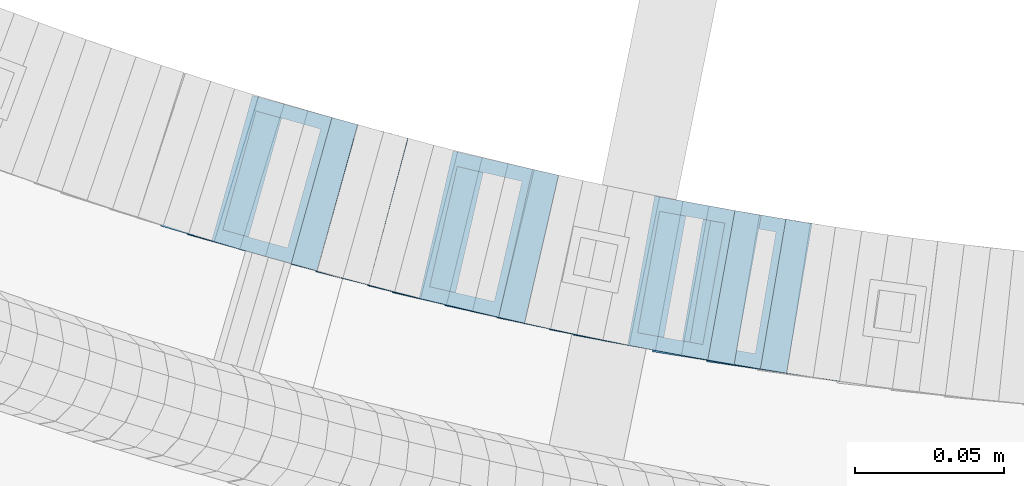
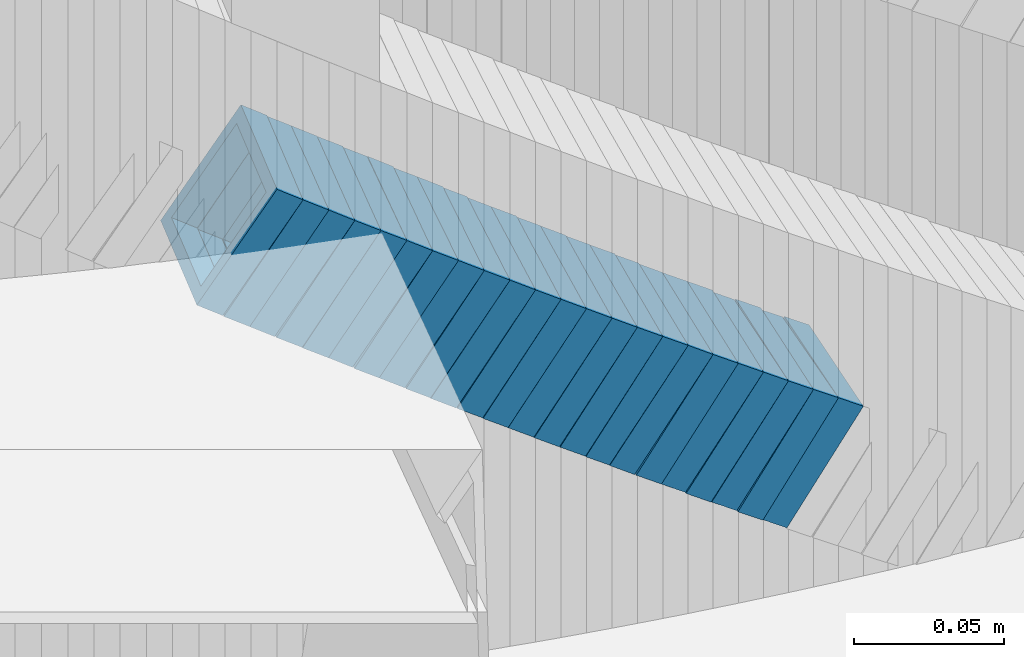
# One storey, part 696 of 975: 23 members.
"""IFC2X3 building model written with IfcOpenShell, lengths in millimetres."""

from ifc_helpers import new_model, si_unit, frame, origin_with_axes, place, context, subcontext, project, spatial, faceted_brep, material, type_object, element, save


model = new_model("IFC2X3")

# Units and contexts
model_context = context("Model", 3, precision=1e-05, world=origin_with_axes())
body_context = subcontext(model_context, "Body", "Model", "MODEL_VIEW")
ifc_project = project(units=[si_unit("LENGTHUNIT", "METRE", prefix="MILLI"), si_unit("AREAUNIT", "SQUARE_METRE"), si_unit("VOLUMEUNIT", "CUBIC_METRE"), si_unit("MASSUNIT", "GRAM", prefix="KILO"), si_unit("TIMEUNIT", "SECOND"), si_unit("PLANEANGLEUNIT", "RADIAN"), si_unit("SOLIDANGLEUNIT", "STERADIAN"), si_unit("THERMODYNAMICTEMPERATUREUNIT", "DEGREE_CELSIUS"), si_unit("LUMINOUSINTENSITYUNIT", "LUMEN")], contexts=[model_context])

# Site, building, storey
site_placement = place(None, origin_with_axes())
site = spatial("IfcSite", under=ifc_project, at=site_placement, CompositionType="ELEMENT")
building_placement = place(site_placement, origin_with_axes())
building = spatial("IfcBuilding", under=site, at=building_placement, Name="Undefined", CompositionType="ELEMENT")
storey_placement = place(building_placement, origin_with_axes())
storey = spatial("IfcBuildingStorey", under=building, at=storey_placement, Name="Undefined", CompositionType="ELEMENT", Elevation=0.0)

# Members
ifc_material = material()
member_type = type_object("IfcMemberType", Name="HSS2X2X.188_TUBES", PredefinedType="NOTDEFINED")
member_1_placement = place(storey_placement, frame((34331.0974043812, 2065.91835474351, 3551.88028193762), z_axis=(-0.279142363058039, -0.960249728532309, 1.20638560474617e-10), x_axis=(-0.805994231967301, 0.234300648990504, 0.543577504977965)))
element("IfcMember", 1, at=member_1_placement, inside=storey, type_object=member_type, material=ifc_material, Name="WALL", ObjectType="HSS2X2X.188_TUBES", context=body_context, shape_type="Brep", body=[
    faceted_brep([(0.0, 20.6374999999753, -20.6375000000298), (0.0, -20.6375000000153, -20.6375000000153), (10.6709887076922, -20.6374999999844, -20.6374999999825), (10.6709887076995, 20.6375000000171, -20.6374999999753), (0.0, -20.6374999999825, 20.6375000000335), (10.6709887076922, -20.6374999999971, 20.6375000000153), (0.0, 20.6375000000116, 20.6375000000189), (10.6709887076941, 20.6375000000025, 20.6375000000189), (0.0, 25.3999999999724, -25.4000000000342), (0.0, 25.400000000016, 25.4000000000196), (10.6709887076959, 25.3999999999996, 25.4000000000233), (10.6709887077013, 25.4000000000178, -25.3999999999724), (0.0, -25.399999999976, 25.4000000000378), (10.6709887076904, -25.3999999999978, 25.400000000016), (0.0, -25.400000000016, -25.4000000000196), (10.6709887076959, -25.3999999999796, -25.3999999999796)], [[[0, 1, 2, 3]], [[1, 4, 5, 2]], [[4, 6, 7, 5]], [[6, 0, 3, 7]], [[8, 9, 10, 11]], [[9, 12, 13, 10]], [[12, 14, 15, 13]], [[14, 8, 11, 15]], [[13, 15, 11, 10], [5, 7, 3, 2]], [[14, 12, 9, 8], [6, 4, 1, 0]]]),
])
member_2_placement = place(storey_placement, frame((34339.5281261376, 2063.41295702112, 3546.09074375081), z_axis=(-0.268798967652496, -0.96319630137836, -2.7861005946761e-10), x_axis=(-0.811862852083943, 0.226566377023422, 0.538095146055609)))
element("IfcMember", 2, at=member_2_placement, inside=storey, type_object=member_type, material=ifc_material, Name="WALL", ObjectType="HSS2X2X.188_TUBES", context=body_context, shape_type="Brep", body=[
    faceted_brep([(0.0, 20.6374999999753, -20.6375000000298), (0.0, -20.6375000000153, -20.6375000000153), (10.5948100501191, -20.6375000000335, -20.6375000000844), (10.5948100501555, 20.6374999999971, -20.6375000000116), (0.0, -20.6374999999825, 20.6375000000335), (10.5948100501446, -20.6375000000098, 20.6374999999571), (0.0, 20.6375000000116, 20.6375000000189), (10.5948100501828, 20.6375000000189, 20.6375000000298), (0.0, 25.3999999999724, -25.4000000000342), (0.0, 25.400000000016, 25.4000000000196), (10.5948100501919, 25.4000000000251, 25.4000000000451), (10.5948100501591, 25.3999999999978, -25.4000000000051), (0.0, -25.399999999976, 25.4000000000378), (10.5948100501482, -25.4000000000106, 25.3999999999578), (0.0, -25.400000000016, -25.4000000000196), (10.5948100501118, -25.4000000000378, -25.400000000096)], [[[0, 1, 2, 3]], [[1, 4, 5, 2]], [[4, 6, 7, 5]], [[6, 0, 3, 7]], [[8, 9, 10, 11]], [[9, 12, 13, 10]], [[12, 14, 15, 13]], [[14, 8, 11, 15]], [[13, 15, 11, 10], [5, 7, 3, 2]], [[14, 12, 9, 8], [6, 4, 1, 0]]]),
])
member_3_placement = place(storey_placement, frame((34347.9652882428, 2061.05840015453, 3540.39961551129), z_axis=(-0.268798967652496, -0.96319630137836, -2.7861005946761e-10), x_axis=(-0.80773431354215, 0.22541422687225, 0.544751048691214)))
element("IfcMember", 3, at=member_3_placement, inside=storey, type_object=member_type, material=ifc_material, Name="WALL", ObjectType="HSS2X2X.188_TUBES", context=body_context, shape_type="Brep", body=[
    faceted_brep([(0.0, 20.6374999999753, -20.6375000000298), (0.0, -20.6375000000153, -20.6375000000153), (10.648004507897, -20.6374999999862, -20.637499999968), (10.6480045078188, 20.6374999999771, -20.6375000000808), (0.0, -20.6374999999825, 20.6375000000335), (10.6480045079406, -20.6374999999698, 20.6375000001062), (0.0, 20.6375000000116, 20.6375000000189), (10.6480045078679, 20.6374999999935, 20.6375000000007), (0.0, 25.3999999999724, -25.4000000000342), (0.0, 25.400000000016, 25.4000000000196), (10.6480045078661, 25.3999999999905, 25.4000000000015), (10.648004507806, 25.3999999999705, -25.4000000000997), (0.0, -25.399999999976, 25.4000000000378), (10.6480045079552, -25.3999999999633, 25.4000000001288), (0.0, -25.400000000016, -25.4000000000196), (10.6480045078988, -25.3999999999814, -25.3999999999651)], [[[0, 1, 2, 3]], [[1, 4, 5, 2]], [[4, 6, 7, 5]], [[6, 0, 3, 7]], [[8, 9, 10, 11]], [[9, 12, 13, 10]], [[12, 14, 15, 13]], [[14, 8, 11, 15]], [[13, 15, 11, 10], [5, 7, 3, 2]], [[14, 12, 9, 8], [6, 4, 1, 0]]]),
])
member_4_placement = place(storey_placement, frame((34356.8447522431, 2058.56625931659, 3534.52460536502), z_axis=(-0.265928998080432, -0.963992618218593, 1.22554411063902e-11), x_axis=(-0.815044169709422, 0.224839770919824, 0.533994455809609)))
element("IfcMember", 4, at=member_4_placement, inside=storey, type_object=member_type, material=ifc_material, Name="WALL", ObjectType="HSS2X2X.188_TUBES", context=body_context, shape_type="Brep", body=[
    faceted_brep([(0.0, 20.6374999999753, -20.6375000000298), (0.0, -20.6375000000153, -20.6375000000153), (10.6709887076922, -20.6374999999844, -20.6374999999825), (10.6709887076995, 20.6375000000171, -20.6374999999753), (0.0, -20.6374999999825, 20.6375000000335), (10.6709887076922, -20.6374999999971, 20.6375000000153), (0.0, 20.6375000000116, 20.6375000000189), (10.6709887076941, 20.6375000000025, 20.6375000000189), (0.0, 25.3999999999724, -25.4000000000342), (0.0, 25.400000000016, 25.4000000000196), (10.6709887076959, 25.3999999999996, 25.4000000000233), (10.6709887077013, 25.4000000000178, -25.3999999999724), (0.0, -25.399999999976, 25.4000000000378), (10.6709887076904, -25.3999999999978, 25.400000000016), (0.0, -25.400000000016, -25.4000000000196), (10.6709887076959, -25.3999999999796, -25.3999999999796)], [[[0, 1, 2, 3]], [[1, 4, 5, 2]], [[4, 6, 7, 5]], [[6, 0, 3, 7]], [[8, 9, 10, 11]], [[9, 12, 13, 10]], [[12, 14, 15, 13]], [[14, 8, 11, 15]], [[13, 15, 11, 10], [5, 7, 3, 2]], [[14, 12, 9, 8], [6, 4, 1, 0]]]),
])
member_5_placement = place(storey_placement, frame((34365.2170506888, 2056.2041123414, 3528.84235404607), z_axis=(-0.255587111130459, -0.966786030424513, 1.11640474642627e-11), x_axis=(-0.81673040781737, 0.215917233951713, 0.535099232880326)))
element("IfcMember", 5, at=member_5_placement, inside=storey, type_object=member_type, material=ifc_material, Name="WALL", ObjectType="HSS2X2X.188_TUBES", context=body_context, shape_type="Brep", body=[
    faceted_brep([(0.0, 20.6374999999753, -20.6375000000298), (0.0, -20.6375000000153, -20.6375000000153), (10.648004507897, -20.6374999999862, -20.637499999968), (10.6480045078188, 20.6374999999771, -20.6375000000808), (0.0, -20.6374999999825, 20.6375000000335), (10.6480045079406, -20.6374999999698, 20.6375000001062), (0.0, 20.6375000000116, 20.6375000000189), (10.6480045078679, 20.6374999999935, 20.6375000000007), (0.0, 25.3999999999724, -25.4000000000342), (0.0, 25.400000000016, 25.4000000000196), (10.6480045078661, 25.3999999999905, 25.4000000000015), (10.648004507806, 25.3999999999705, -25.4000000000997), (0.0, -25.399999999976, 25.4000000000378), (10.6480045079552, -25.3999999999633, 25.4000000001288), (0.0, -25.400000000016, -25.4000000000196), (10.6480045078988, -25.3999999999814, -25.3999999999651)], [[[0, 1, 2, 3]], [[1, 4, 5, 2]], [[4, 6, 7, 5]], [[6, 0, 3, 7]], [[8, 9, 10, 11]], [[9, 12, 13, 10]], [[12, 14, 15, 13]], [[14, 8, 11, 15]], [[13, 15, 11, 10], [5, 7, 3, 2]], [[14, 12, 9, 8], [6, 4, 1, 0]]]),
])
member_6_placement = place(storey_placement, frame((34373.6329246341, 2053.99385694625, 3523.21833437151), z_axis=(-0.258361739614913, -0.966048244914899, -2.28051248996053e-10), x_axis=(-0.809414005296683, 0.216471187079332, 0.545883864200112)))
element("IfcMember", 6, at=member_6_placement, inside=storey, type_object=member_type, material=ifc_material, Name="WALL", ObjectType="HSS2X2X.188_TUBES", context=body_context, shape_type="Brep", body=[
    faceted_brep([(0.0, 20.6374999999753, -20.6375000000298), (0.0, -20.6375000000153, -20.6375000000153), (10.6216759506497, -20.637499999968, -20.6374999999534), (10.6216759506497, 20.6375000000262, -20.6374999999643), (0.0, -20.6374999999825, 20.6375000000335), (10.6216759506169, -20.6374999999935, 20.637500000008), (0.0, 20.6375000000116, 20.6375000000189), (10.6216759506242, 20.6375000000007, 20.6374999999971), (0.0, 25.3999999999724, -25.4000000000342), (0.0, 25.400000000016, 25.4000000000196), (10.6216759506169, 25.3999999999978, 25.3999999999869), (10.6216759506533, 25.4000000000269, -25.3999999999614), (0.0, -25.399999999976, 25.4000000000378), (10.6216759506242, -25.3999999999942, 25.4000000000051), (0.0, -25.400000000016, -25.4000000000196), (10.6216759506569, -25.3999999999614, -25.3999999999432)], [[[0, 1, 2, 3]], [[1, 4, 5, 2]], [[4, 6, 7, 5]], [[6, 0, 3, 7]], [[8, 9, 10, 11]], [[9, 12, 13, 10]], [[12, 14, 15, 13]], [[14, 8, 11, 15]], [[13, 15, 11, 10], [5, 7, 3, 2]], [[14, 12, 9, 8], [6, 4, 1, 0]]]),
])
member_7_placement = place(storey_placement, frame((34382.1892508265, 2051.63748919236, 3517.35949972849), z_axis=(-0.245156736609686, -0.969483457566393, 4.429666660144e-10), x_axis=(-0.818354737867747, 0.206940278966542, 0.536163448913352)))
element("IfcMember", 7, at=member_7_placement, inside=storey, type_object=member_type, material=ifc_material, Name="WALL", ObjectType="HSS2X2X.188_TUBES", context=body_context, shape_type="Brep", body=[
    faceted_brep([(0.0, 20.6374999999753, -20.6375000000298), (0.0, -20.6375000000153, -20.6375000000153), (10.6348483769107, -20.637499999988, -20.6374999999825), (10.6348483768415, 20.6374999999734, -20.6375000001026), (0.0, -20.6374999999825, 20.6375000000335), (10.6348483769852, -20.6374999999589, 20.6375000001462), (0.0, 20.6375000000116, 20.6375000000189), (10.6348483769161, 20.6375000000044, 20.6375000000226), (0.0, 25.3999999999724, -25.4000000000342), (0.0, 25.400000000016, 25.4000000000196), (10.6348483769179, 25.4000000000015, 25.4000000000233), (10.6348483768288, 25.3999999999669, -25.4000000001324), (0.0, -25.399999999976, 25.4000000000378), (10.6348483769998, -25.3999999999505, 25.4000000001688), (0.0, -25.400000000016, -25.4000000000196), (10.6348483769107, -25.3999999999887, -25.3999999999833)], [[[0, 1, 2, 3]], [[1, 4, 5, 2]], [[4, 6, 7, 5]], [[6, 0, 3, 7]], [[8, 9, 10, 11]], [[9, 12, 13, 10]], [[12, 14, 15, 13]], [[14, 8, 11, 15]], [[13, 15, 11, 10], [5, 7, 3, 2]], [[14, 12, 9, 8], [6, 4, 1, 0]]]),
])
member_8_placement = place(storey_placement, frame((34390.7254524821, 2049.47890946337, 3511.66775487245), z_axis=(-0.245156736609686, -0.969483457566393, 4.429666660144e-10), x_axis=(-0.814222786177676, 0.205895417044948, 0.542815191118441)))
element("IfcMember", 8, at=member_8_placement, inside=storey, type_object=member_type, material=ifc_material, Name="WALL", ObjectType="HSS2X2X.188_TUBES", context=body_context, shape_type="Brep", body=[
    faceted_brep([(0.0, 20.6374999999753, -20.6375000000298), (0.0, -20.6375000000153, -20.6375000000153), (10.6906501205649, -20.6374999999844, -20.637499999968), (10.690650120574, 20.6375000000098, -20.6374999999716), (0.0, -20.6374999999825, 20.6375000000335), (10.6906501205467, -20.6374999999844, 20.637500000008), (0.0, 20.6375000000116, 20.6375000000189), (10.6906501205558, 20.637500000008, 20.6375000000007), (0.0, 25.3999999999724, -25.4000000000342), (0.0, 25.400000000016, 25.4000000000196), (10.6906501205522, 25.4000000000087, 25.3999999999978), (10.6906501205813, 25.4000000000124, -25.3999999999651), (0.0, -25.399999999976, 25.4000000000378), (10.6906501205431, -25.3999999999833, 25.4000000000051), (0.0, -25.400000000016, -25.4000000000196), (10.6906501205704, -25.3999999999833, -25.3999999999614)], [[[0, 1, 2, 3]], [[1, 4, 5, 2]], [[4, 6, 7, 5]], [[6, 0, 3, 7]], [[8, 9, 10, 11]], [[9, 12, 13, 10]], [[12, 14, 15, 13]], [[14, 8, 11, 15]], [[13, 15, 11, 10], [5, 7, 3, 2]], [[14, 12, 9, 8], [6, 4, 1, 0]]]),
])
member_9_placement = place(storey_placement, frame((34399.2614923922, 2047.26637819976, 3505.87602440477), z_axis=(-0.23464053291006, -0.972082208620075, 1.09321263153106e-12), x_axis=(-0.819915965339719, 0.197910750081997, 0.537186322222577)))
element("IfcMember", 9, at=member_9_placement, inside=storey, type_object=member_type, material=ifc_material, Name="WALL", ObjectType="HSS2X2X.188_TUBES", context=body_context, shape_type="Brep", body=[
    faceted_brep([(0.0, 20.6374999999753, -20.6375000000298), (0.0, -20.6375000000153, -20.6375000000153), (10.6061303028146, -20.6374999999571, -20.6374999999643), (10.6061303027491, 20.6374999999971, -20.6375000000007), (0.0, -20.6374999999825, 20.6375000000335), (10.6061303027855, -20.6374999999825, 20.6375000000116), (0.0, 20.6375000000116, 20.6375000000189), (10.6061303027236, 20.637499999968, 20.6374999999716), (0.0, 25.3999999999724, -25.4000000000342), (0.0, 25.400000000016, 25.4000000000196), (10.6061303027163, 25.3999999999651, 25.3999999999651), (10.6061303027454, 25.3999999999942, -25.4000000000051), (0.0, -25.399999999976, 25.4000000000378), (10.6061303027891, -25.3999999999796, 25.4000000000124), (0.0, -25.400000000016, -25.4000000000196), (10.6061303028182, -25.3999999999505, -25.3999999999542)], [[[0, 1, 2, 3]], [[1, 4, 5, 2]], [[4, 6, 7, 5]], [[6, 0, 3, 7]], [[8, 9, 10, 11]], [[9, 12, 13, 10]], [[12, 14, 15, 13]], [[14, 8, 11, 15]], [[13, 15, 11, 10], [5, 7, 3, 2]], [[14, 12, 9, 8], [6, 4, 1, 0]]]),
])
member_10_placement = place(storey_placement, frame((34407.4691510217, 2045.22865012642, 3500.20080520356), z_axis=(-0.224041298984492, -0.974579651105717, -2.52057361649349e-11), x_axis=(-0.817234718278173, 0.187870050063947, 0.544823145185449)))
element("IfcMember", 10, at=member_10_placement, inside=storey, type_object=member_type, material=ifc_material, Name="WALL", ObjectType="HSS2X2X.188_TUBES", context=body_context, shape_type="Brep", body=[
    faceted_brep([(0.0, 20.6374999999753, -20.6375000000298), (0.0, -20.6375000000153, -20.6375000000153), (10.648004507897, -20.6374999999862, -20.637499999968), (10.6480045078188, 20.6374999999771, -20.6375000000808), (0.0, -20.6374999999825, 20.6375000000335), (10.6480045079406, -20.6374999999698, 20.6375000001062), (0.0, 20.6375000000116, 20.6375000000189), (10.6480045078679, 20.6374999999935, 20.6375000000007), (0.0, 25.3999999999724, -25.4000000000342), (0.0, 25.400000000016, 25.4000000000196), (10.6480045078661, 25.3999999999905, 25.4000000000015), (10.648004507806, 25.3999999999705, -25.4000000000997), (0.0, -25.399999999976, 25.4000000000378), (10.6480045079552, -25.3999999999633, 25.4000000001288), (0.0, -25.400000000016, -25.4000000000196), (10.6480045078988, -25.3999999999814, -25.3999999999651)], [[[0, 1, 2, 3]], [[1, 4, 5, 2]], [[4, 6, 7, 5]], [[6, 0, 3, 7]], [[8, 9, 10, 11]], [[9, 12, 13, 10]], [[12, 14, 15, 13]], [[14, 8, 11, 15]], [[13, 15, 11, 10], [5, 7, 3, 2]], [[14, 12, 9, 8], [6, 4, 1, 0]]]),
])
member_11_placement = place(storey_placement, frame((34416.3339171197, 2043.1907728625, 3494.39191048429), z_axis=(-0.224041298984492, -0.974579651105717, -2.52057361649349e-11), x_axis=(-0.82141292979664, 0.188830558953255, 0.538167091866738)))
element("IfcMember", 11, at=member_11_placement, inside=storey, type_object=member_type, material=ifc_material, Name="WALL", ObjectType="HSS2X2X.188_TUBES", context=body_context, shape_type="Brep", body=[
    faceted_brep([(0.0, 20.6374999999753, -20.6375000000298), (0.0, -20.6375000000153, -20.6375000000153), (10.5948100501191, -20.6375000000335, -20.6375000000844), (10.5948100501555, 20.6374999999971, -20.6375000000116), (0.0, -20.6374999999825, 20.6375000000335), (10.5948100501446, -20.6375000000098, 20.6374999999571), (0.0, 20.6375000000116, 20.6375000000189), (10.5948100501828, 20.6375000000189, 20.6375000000298), (0.0, 25.3999999999724, -25.4000000000342), (0.0, 25.400000000016, 25.4000000000196), (10.5948100501919, 25.4000000000251, 25.4000000000451), (10.5948100501591, 25.3999999999978, -25.4000000000051), (0.0, -25.399999999976, 25.4000000000378), (10.5948100501482, -25.4000000000106, 25.3999999999578), (0.0, -25.400000000016, -25.4000000000196), (10.5948100501118, -25.4000000000378, -25.400000000096)], [[[0, 1, 2, 3]], [[1, 4, 5, 2]], [[4, 6, 7, 5]], [[6, 0, 3, 7]], [[8, 9, 10, 11]], [[9, 12, 13, 10]], [[12, 14, 15, 13]], [[14, 8, 11, 15]], [[13, 15, 11, 10], [5, 7, 3, 2]], [[14, 12, 9, 8], [6, 4, 1, 0]]]),
])
member_12_placement = place(storey_placement, frame((34424.7066685001, 2041.21067197562, 3488.70714083713), z_axis=(-0.213361967337347, -0.976973219128312, 1.93437699635979e-10), x_axis=(-0.822844507376832, 0.179701674082304, 0.539105022246868)))
element("IfcMember", 12, at=member_12_placement, inside=storey, type_object=member_type, material=ifc_material, Name="WALL", ObjectType="HSS2X2X.188_TUBES", context=body_context, shape_type="Brep", body=[
    faceted_brep([(0.0, 20.6374999999753, -20.6375000000298), (0.0, -20.6375000000153, -20.6375000000153), (10.5744976239494, -20.6375000000207, -20.6375000000335), (10.5744976239657, 20.6375000000098, -20.637500000008), (0.0, -20.6374999999825, 20.6375000000335), (10.5744976239639, -20.6375000000244, 20.6374999999753), (0.0, 20.6375000000116, 20.6375000000189), (10.5744976239803, 20.6374999999989, 20.6374999999935), (0.0, 25.3999999999724, -25.4000000000342), (0.0, 25.400000000016, 25.4000000000196), (10.5744976239857, 25.4000000000051, 25.4000000000015), (10.5744976239675, 25.4000000000124, -25.4000000000051), (0.0, -25.399999999976, 25.4000000000378), (10.5744976239639, -25.4000000000287, 25.3999999999724), (0.0, -25.400000000016, -25.4000000000196), (10.5744976239494, -25.4000000000215, -25.4000000000378)], [[[0, 1, 2, 3]], [[1, 4, 5, 2]], [[4, 6, 7, 5]], [[6, 0, 3, 7]], [[8, 9, 10, 11]], [[9, 12, 13, 10]], [[12, 14, 15, 13]], [[14, 8, 11, 15]], [[13, 15, 11, 10], [5, 7, 3, 2]], [[14, 12, 9, 8], [6, 4, 1, 0]]]),
])
member_13_placement = place(storey_placement, frame((34433.3794269946, 2039.30501729349, 3482.94756297377), z_axis=(-0.211045983876436, -0.977476134076749, -8.82473614183254e-11), x_axis=(-0.821712504265793, 0.177415200057388, 0.541583241175202)))
element("IfcMember", 13, at=member_13_placement, inside=storey, type_object=member_type, material=ifc_material, Name="WALL", ObjectType="HSS2X2X.188_TUBES", context=body_context, shape_type="Brep", body=[
    faceted_brep([(0.0, 20.6374999999753, -20.6375000000298), (0.0, -20.6375000000153, -20.6375000000153), (10.7093417165161, -20.637499999968, -20.6374999999534), (10.709341716436, 20.6374999999898, -20.6375000000116), (0.0, -20.6374999999825, 20.6375000000335), (10.7093417164688, -20.6374999999971, 20.6375000000153), (0.0, 20.6375000000116, 20.6375000000189), (10.7093417163924, 20.6374999999643, 20.6374999999571), (0.0, 25.3999999999724, -25.4000000000342), (0.0, 25.400000000016, 25.4000000000196), (10.7093417163815, 25.3999999999542, 25.3999999999469), (10.7093417164288, 25.3999999999869, -25.4000000000196), (0.0, -25.399999999976, 25.4000000000378), (10.7093417164724, -25.3999999999942, 25.4000000000196), (0.0, -25.400000000016, -25.4000000000196), (10.709341716527, -25.3999999999578, -25.3999999999432)], [[[0, 1, 2, 3]], [[1, 4, 5, 2]], [[4, 6, 7, 5]], [[6, 0, 3, 7]], [[8, 9, 10, 11]], [[9, 12, 13, 10]], [[12, 14, 15, 13]], [[14, 8, 11, 15]], [[13, 15, 11, 10], [5, 7, 3, 2]], [[14, 12, 9, 8], [6, 4, 1, 0]]]),
])
member_14_placement = place(storey_placement, frame((34441.8798915298, 2037.42607974427, 3477.22169883749), z_axis=(-0.202605604136544, -0.979260419486291, 1.52564552990952e-10), x_axis=(-0.824209612871584, 0.170526126973434, 0.539999401915885)))
element("IfcMember", 14, at=member_14_placement, inside=storey, type_object=member_type, material=ifc_material, Name="WALL", ObjectType="HSS2X2X.188_TUBES", context=body_context, shape_type="Brep", body=[
    faceted_brep([(0.0, 20.6374999999753, -20.6375000000298), (0.0, -20.6375000000153, -20.6375000000153), (10.5550935571373, -20.6374999999935, -20.6374999999753), (10.5550935571373, 20.6375000000025, -20.6374999999862), (0.0, -20.6374999999825, 20.6375000000335), (10.5550935571027, -20.6374999999989, 20.6374999999862), (0.0, 20.6375000000116, 20.6375000000189), (10.5550935571027, 20.6374999999953, 20.6374999999716), (0.0, 25.3999999999724, -25.4000000000342), (0.0, 25.400000000016, 25.4000000000196), (10.5550935570991, 25.3999999999924, 25.3999999999651), (10.5550935571373, 25.3999999999996, -25.3999999999905), (0.0, -25.399999999976, 25.4000000000378), (10.5550935571009, -25.3999999999996, 25.3999999999833), (0.0, -25.400000000016, -25.4000000000196), (10.5550935571428, -25.3999999999905, -25.3999999999724)], [[[0, 1, 2, 3]], [[1, 4, 5, 2]], [[4, 6, 7, 5]], [[6, 0, 3, 7]], [[8, 9, 10, 11]], [[9, 12, 13, 10]], [[12, 14, 15, 13]], [[14, 8, 11, 15]], [[13, 15, 11, 10], [5, 7, 3, 2]], [[14, 12, 9, 8], [6, 4, 1, 0]]]),
])
member_15_placement = place(storey_placement, frame((34450.7218413914, 2035.58598623362, 3471.45376782557), z_axis=(-0.200396236142071, -0.979714932283923, 5.22218215337489e-11), x_axis=(-0.827212358757627, 0.16920252795042, 0.535808004842994)))
element("IfcMember", 15, at=member_15_placement, inside=storey, type_object=member_type, material=ifc_material, Name="WALL", ObjectType="HSS2X2X.188_TUBES", context=body_context, shape_type="Brep", body=[
    faceted_brep([(0.0, 20.6374999999753, -20.6375000000298), (0.0, -20.6375000000153, -20.6375000000153), (10.6395488625676, -20.6374999999771, -20.6374999999716), (10.6395488625531, 20.6374999999916, -20.6375000000189), (0.0, -20.6374999999825, 20.6375000000335), (10.6395488625731, -20.6374999999844, 20.6375000000153), (0.0, 20.6375000000116, 20.6375000000189), (10.6395488625585, 20.6374999999825, 20.637499999968), (0.0, 25.3999999999724, -25.4000000000342), (0.0, 25.400000000016, 25.4000000000196), (10.6395488625567, 25.3999999999778, 25.3999999999614), (10.6395488625494, 25.3999999999887, -25.4000000000233), (0.0, -25.399999999976, 25.4000000000378), (10.6395488625749, -25.3999999999851, 25.400000000016), (0.0, -25.400000000016, -25.4000000000196), (10.6395488625658, -25.399999999976, -25.3999999999687)], [[[0, 1, 2, 3]], [[1, 4, 5, 2]], [[4, 6, 7, 5]], [[6, 0, 3, 7]], [[8, 9, 10, 11]], [[9, 12, 13, 10]], [[12, 14, 15, 13]], [[14, 8, 11, 15]], [[13, 15, 11, 10], [5, 7, 3, 2]], [[14, 12, 9, 8], [6, 4, 1, 0]]]),
])
member_16_placement = place(storey_placement, frame((34459.1997947913, 2033.79822885849, 3465.76716837124), z_axis=(-0.189674976082606, -0.981846934836618, 7.12880137143657e-11), x_axis=(-0.828494490235645, 0.160050072045518, 0.536638476152618)))
element("IfcMember", 16, at=member_16_placement, inside=storey, type_object=member_type, material=ifc_material, Name="WALL", ObjectType="HSS2X2X.188_TUBES", context=body_context, shape_type="Brep", body=[
    faceted_brep([(0.0, 20.6374999999753, -20.6375000000298), (0.0, -20.6375000000153, -20.6375000000153), (10.6216759506497, -20.637499999968, -20.6374999999534), (10.6216759506497, 20.6375000000262, -20.6374999999643), (0.0, -20.6374999999825, 20.6375000000335), (10.6216759506169, -20.6374999999935, 20.637500000008), (0.0, 20.6375000000116, 20.6375000000189), (10.6216759506242, 20.6375000000007, 20.6374999999971), (0.0, 25.3999999999724, -25.4000000000342), (0.0, 25.400000000016, 25.4000000000196), (10.6216759506169, 25.3999999999978, 25.3999999999869), (10.6216759506533, 25.4000000000269, -25.3999999999614), (0.0, -25.399999999976, 25.4000000000378), (10.6216759506242, -25.3999999999942, 25.4000000000051), (0.0, -25.400000000016, -25.4000000000196), (10.6216759506569, -25.3999999999614, -25.3999999999432)], [[[0, 1, 2, 3]], [[1, 4, 5, 2]], [[4, 6, 7, 5]], [[6, 0, 3, 7]], [[8, 9, 10, 11]], [[9, 12, 13, 10]], [[12, 14, 15, 13]], [[14, 8, 11, 15]], [[13, 15, 11, 10], [5, 7, 3, 2]], [[14, 12, 9, 8], [6, 4, 1, 0]]]),
])
member_17_placement = place(storey_placement, frame((34467.3618892993, 2032.1740770404, 3460.15874108679), z_axis=(-0.180874694051396, -0.983506148964923, 3.73033799405675e-11), x_axis=(-0.822476722982534, 0.151260086996791, 0.548317814988383)))
element("IfcMember", 17, at=member_17_placement, inside=storey, type_object=member_type, material=ifc_material, Name="WALL", ObjectType="HSS2X2X.188_TUBES", context=body_context, shape_type="Brep", body=[
    faceted_brep([(0.0, 20.6374999999753, -20.6375000000298), (0.0, -20.6375000000153, -20.6375000000153), (10.5806427026419, -20.6374999999607, -20.6374999999316), (10.5806427026473, 20.6375000000444, -20.6374999999207), (0.0, -20.6374999999825, 20.6375000000335), (10.5806427025509, -20.6375000000207, 20.6374999999643), (0.0, 20.6375000000116, 20.6375000000189), (10.5806427025545, 20.6374999999862, 20.6374999999716), (0.0, 25.3999999999724, -25.4000000000342), (0.0, 25.400000000016, 25.4000000000196), (10.5806427025436, 25.3999999999796, 25.3999999999614), (10.5806427026582, 25.4000000000542, -25.3999999999105), (0.0, -25.399999999976, 25.4000000000378), (10.5806427025418, -25.4000000000287, 25.3999999999542), (0.0, -25.400000000016, -25.4000000000196), (10.5806427026528, -25.3999999999542, -25.3999999999178)], [[[0, 1, 2, 3]], [[1, 4, 5, 2]], [[4, 6, 7, 5]], [[6, 0, 3, 7]], [[8, 9, 10, 11]], [[9, 12, 13, 10]], [[12, 14, 15, 13]], [[14, 8, 11, 15]], [[13, 15, 11, 10], [5, 7, 3, 2]], [[14, 12, 9, 8], [6, 4, 1, 0]]]),
])
for number, where, z_axis, x_axis, name in (
    (18, (34476.3785096792, 2030.50611826858, 3454.27988729621), (-0.178885438594422, -0.983869910028191, 3.69490862794919e-10), (-0.829708833093973, 0.150856152017093, 0.537425040060876), "WALL"),
    (19, (34485.1785096792, 2028.90611826857, 3448.5798872962), (-0.178885438594422, -0.983869910028191, 3.69490862794919e-10), (-0.829708833093973, 0.150856152017093, 0.537425040060876), "WALL"),
):
    element("IfcMember", number, at=place(storey_placement, frame(where, z_axis=z_axis, x_axis=x_axis)), inside=storey, type_object=member_type, material=ifc_material, Name=name, ObjectType="HSS2X2X.188_TUBES", context=body_context, shape_type="Brep", body=[
        faceted_brep([(0.0, 20.6374999999753, -20.6375000000298), (0.0, -20.6375000000153, -20.6375000000153), (10.6061303028146, -20.6374999999571, -20.6374999999643), (10.6061303027491, 20.6374999999971, -20.6375000000007), (0.0, -20.6374999999825, 20.6375000000335), (10.6061303027855, -20.6374999999825, 20.6375000000116), (0.0, 20.6375000000116, 20.6375000000189), (10.6061303027236, 20.637499999968, 20.6374999999716), (0.0, 25.3999999999724, -25.4000000000342), (0.0, 25.400000000016, 25.4000000000196), (10.6061303027163, 25.3999999999651, 25.3999999999651), (10.6061303027454, 25.3999999999942, -25.4000000000051), (0.0, -25.399999999976, 25.4000000000378), (10.6061303027891, -25.3999999999796, 25.4000000000124), (0.0, -25.400000000016, -25.4000000000196), (10.6061303028182, -25.3999999999505, -25.3999999999542)], [[[0, 1, 2, 3]], [[1, 4, 5, 2]], [[4, 6, 7, 5]], [[6, 0, 3, 7]], [[8, 9, 10, 11]], [[9, 12, 13, 10]], [[12, 14, 15, 13]], [[14, 8, 11, 15]], [[13, 15, 11, 10], [5, 7, 3, 2]], [[14, 12, 9, 8], [6, 4, 1, 0]]]),
    ])
member_18_placement = place(storey_placement, frame((34493.1717951905, 2027.33549450349, 3442.91234156434), z_axis=(-0.157115048901796, -0.987580306308599, -9.46861291595269e-11), x_axis=(-0.827687883657579, 0.131677617945529, 0.54552155977434)))
element("IfcMember", 20, at=member_18_placement, inside=storey, type_object=member_type, material=ifc_material, Name="WALL", ObjectType="HSS2X2X.188_TUBES", context=body_context, shape_type="Brep", body=[
    faceted_brep([(0.0, 20.6374999999753, -20.6375000000298), (0.0, -20.6375000000153, -20.6375000000153), (10.6348483769107, -20.637499999988, -20.6374999999825), (10.6348483768415, 20.6374999999734, -20.6375000001026), (0.0, -20.6374999999825, 20.6375000000335), (10.6348483769852, -20.6374999999589, 20.6375000001462), (0.0, 20.6375000000116, 20.6375000000189), (10.6348483769161, 20.6375000000044, 20.6375000000226), (0.0, 25.3999999999724, -25.4000000000342), (0.0, 25.400000000016, 25.4000000000196), (10.6348483769179, 25.4000000000015, 25.4000000000233), (10.6348483768288, 25.3999999999669, -25.4000000001324), (0.0, -25.399999999976, 25.4000000000378), (10.6348483769998, -25.3999999999505, 25.4000000001688), (0.0, -25.400000000016, -25.4000000000196), (10.6348483769107, -25.3999999999887, -25.3999999999833)], [[[0, 1, 2, 3]], [[1, 4, 5, 2]], [[4, 6, 7, 5]], [[6, 0, 3, 7]], [[8, 9, 10, 11]], [[9, 12, 13, 10]], [[12, 14, 15, 13]], [[14, 8, 11, 15]], [[13, 15, 11, 10], [5, 7, 3, 2]], [[14, 12, 9, 8], [6, 4, 1, 0]]]),
])
member_19_placement = place(storey_placement, frame((34502.4581288693, 2025.90967530683, 3437.0919104843), z_axis=(-0.168030974253103, -0.985781716046485, 1.54325334733585e-10), x_axis=(-0.830854457802135, 0.141622918966268, 0.53816709187184)))
element("IfcMember", 21, at=member_19_placement, inside=storey, type_object=member_type, material=ifc_material, Name="WALL", ObjectType="HSS2X2X.188_TUBES", context=body_context, shape_type="Brep", body=[
    faceted_brep([(0.0, 20.6374999999753, -20.6375000000298), (0.0, -20.6375000000153, -20.6375000000153), (10.5948100501191, -20.6375000000335, -20.6375000000844), (10.5948100501555, 20.6374999999971, -20.6375000000116), (0.0, -20.6374999999825, 20.6375000000335), (10.5948100501446, -20.6375000000098, 20.6374999999571), (0.0, 20.6375000000116, 20.6375000000189), (10.5948100501828, 20.6375000000189, 20.6375000000298), (0.0, 25.3999999999724, -25.4000000000342), (0.0, 25.400000000016, 25.4000000000196), (10.5948100501919, 25.4000000000251, 25.4000000000451), (10.5948100501591, 25.3999999999978, -25.4000000000051), (0.0, -25.399999999976, 25.4000000000378), (10.5948100501482, -25.4000000000106, 25.3999999999578), (0.0, -25.400000000016, -25.4000000000196), (10.5948100501118, -25.4000000000378, -25.400000000096)], [[[0, 1, 2, 3]], [[1, 4, 5, 2]], [[4, 6, 7, 5]], [[6, 0, 3, 7]], [[8, 9, 10, 11]], [[9, 12, 13, 10]], [[12, 14, 15, 13]], [[14, 8, 11, 15]], [[13, 15, 11, 10], [5, 7, 3, 2]], [[14, 12, 9, 8], [6, 4, 1, 0]]]),
])
member_20_placement = place(storey_placement, frame((34510.7828346098, 2024.37235213003, 3431.34539122227), z_axis=(-0.144533690370161, -0.989499879913071, 2.40080680669053e-10), x_axis=(-0.83580050451228, 0.122083219928765, 0.535287963687624)))
element("IfcMember", 22, at=member_20_placement, inside=storey, type_object=member_type, material=ifc_material, Name="WALL", ObjectType="HSS2X2X.188_TUBES", context=body_context, shape_type="Brep", body=[
    faceted_brep([(0.0, 20.6374999999753, -20.6375000000298), (0.0, -20.6375000000153, -20.6375000000153), (10.648004507897, -20.6374999999862, -20.637499999968), (10.6480045078188, 20.6374999999771, -20.6375000000808), (0.0, -20.6374999999825, 20.6375000000335), (10.6480045079406, -20.6374999999698, 20.6375000001062), (0.0, 20.6375000000116, 20.6375000000189), (10.6480045078679, 20.6374999999935, 20.6375000000007), (0.0, 25.3999999999724, -25.4000000000342), (0.0, 25.400000000016, 25.4000000000196), (10.6480045078661, 25.3999999999905, 25.4000000000015), (10.648004507806, 25.3999999999705, -25.4000000000997), (0.0, -25.399999999976, 25.4000000000378), (10.6480045079552, -25.3999999999633, 25.4000000001288), (0.0, -25.400000000016, -25.4000000000196), (10.6480045078988, -25.3999999999814, -25.3999999999651)], [[[0, 1, 2, 3]], [[1, 4, 5, 2]], [[4, 6, 7, 5]], [[6, 0, 3, 7]], [[8, 9, 10, 11]], [[9, 12, 13, 10]], [[12, 14, 15, 13]], [[14, 8, 11, 15]], [[13, 15, 11, 10], [5, 7, 3, 2]], [[14, 12, 9, 8], [6, 4, 1, 0]]]),
])
member_21_placement = place(storey_placement, frame((34519.8387955124, 2023.10892627047, 3425.70322446153), z_axis=(-0.157115048901796, -0.987580306308599, -9.46861291595269e-11), x_axis=(-0.831930478100311, 0.132352576015964, 0.538864060064991)))
element("IfcMember", 23, at=member_21_placement, inside=storey, type_object=member_type, material=ifc_material, Name="WALL", ObjectType="HSS2X2X.188_TUBES", context=body_context, shape_type="Brep", body=[
    faceted_brep([(0.0, 20.6374999999753, -20.6375000000298), (0.0, -20.6375000000153, -20.6375000000153), (10.5806427026419, -20.6374999999607, -20.6374999999316), (10.5806427026473, 20.6375000000444, -20.6374999999207), (0.0, -20.6374999999825, 20.6375000000335), (10.5806427025509, -20.6375000000207, 20.6374999999643), (0.0, 20.6375000000116, 20.6375000000189), (10.5806427025545, 20.6374999999862, 20.6374999999716), (0.0, 25.3999999999724, -25.4000000000342), (0.0, 25.400000000016, 25.4000000000196), (10.5806427025436, 25.3999999999796, 25.3999999999614), (10.5806427026582, 25.4000000000542, -25.3999999999105), (0.0, -25.399999999976, 25.4000000000378), (10.5806427025418, -25.4000000000287, 25.3999999999542), (0.0, -25.400000000016, -25.4000000000196), (10.5806427026528, -25.3999999999542, -25.3999999999178)], [[[0, 1, 2, 3]], [[1, 4, 5, 2]], [[4, 6, 7, 5]], [[6, 0, 3, 7]], [[8, 9, 10, 11]], [[9, 12, 13, 10]], [[12, 14, 15, 13]], [[14, 8, 11, 15]], [[13, 15, 11, 10], [5, 7, 3, 2]], [[14, 12, 9, 8], [6, 4, 1, 0]]]),
])

save(model, "model.ifc")
